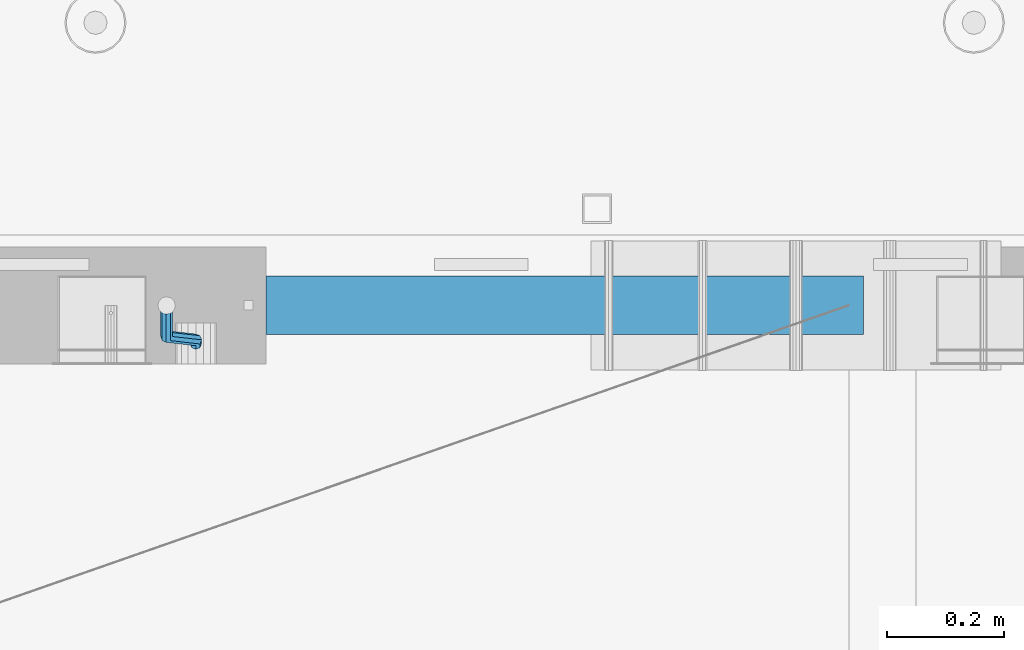
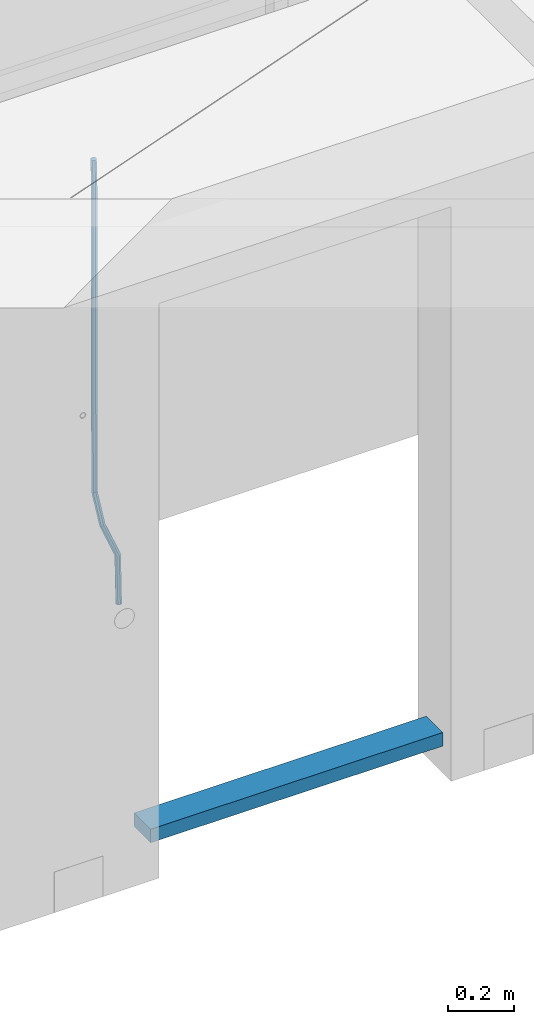
# One storey, part 112 of 349: 2 beams, 1 element without a shape of its own.
"""IFC2X3 building model written with IfcOpenShell, lengths in millimetres."""

import ifcopenshell
import ifcopenshell.guid

model = None  # the IFC model being written
_history = None  # IfcOwnerHistory: only IFC2X3 demands one
_inside = {}  # id of a spatial element -> (the spatial element, [elements in it])
_under = {}  # id of a project, library or spatial element -> (it, [spatial elements below it])
_declared = {}  # id of a project -> (the project, [libraries it declares])
_typed = {}  # id of a type object -> (the type object, [elements of that type])
_made_of = {}  # id of a material, layer set ... -> (it, [elements and type objects made of it])


def new_model(schema):
    """Start an empty IFC model of exactly this schema.

    Asked for "IFC4X3", IfcOpenShell would pick the latest addendum, in which some entities
    have other attributes; the version numbers below select the first issue.
    IFC2X3 requires an IfcOwnerHistory on every rooted entity: one is made here for all.
    """
    global model, _history
    if schema == "IFC4X3":
        model = ifcopenshell.file(schema_version=(4, 3, 0, 0))
    else:
        model = ifcopenshell.file(schema=schema)
    _inside.clear()
    _under.clear()
    _declared.clear()
    _typed.clear()
    _made_of.clear()
    _history = None
    if model.schema == "IFC2X3":
        org = make("IfcOrganization", Name="unknown")
        user = make(
            "IfcPersonAndOrganization",
            ThePerson=make("IfcPerson", FamilyName="unknown"),
            TheOrganization=org,
        )
        app = make(
            "IfcApplication",
            ApplicationDeveloper=org,
            Version="unknown",
            ApplicationFullName="unknown",
            ApplicationIdentifier="unknown",
        )
        _history = make(
            "IfcOwnerHistory",
            OwningUser=user,
            OwningApplication=app,
            ChangeAction="ADDED",
            CreationDate=0,
        )
    return model


def make(cls, **values):
    """One entity of the class cls with the attributes given. An attribute that is None is left unset."""
    return model.create_entity(
        cls, **{name: value for name, value in values.items() if value is not None}
    )


def rooted(cls, **values):
    """An entity with a GlobalId (a new one), such as an element, a storey or a relation."""
    return make(cls, GlobalId=ifcopenshell.guid.new(), OwnerHistory=_history, **values)


def si_unit(unit_type, name, prefix=None):
    """IfcSIUnit, for example si_unit("LENGTHUNIT", "METRE", prefix="MILLI")."""
    return make("IfcSIUnit", UnitType=unit_type, Prefix=prefix, Name=name)


def assignment(units):
    """IfcUnitAssignment: the units of a project."""
    return None if units is None else make("IfcUnitAssignment", Units=units)


def point(xyz):
    """IfcCartesianPoint."""
    return None if xyz is None else make("IfcCartesianPoint", Coordinates=xyz)


def direction(xyz):
    """IfcDirection."""
    return None if xyz is None else make("IfcDirection", DirectionRatios=xyz)


def frame(location, z_axis=None, x_axis=None):
    """IfcAxis2Placement3D, a coordinate frame: its origin and axes. An axis left out is left unset."""
    return make(
        "IfcAxis2Placement3D",
        Location=point(location),
        Axis=direction(z_axis),
        RefDirection=direction(x_axis),
    )


def origin_with_axes():
    """The frame at (0, 0, 0) with the z axis (0, 0, 1) and the x axis (1, 0, 0) written out."""
    return frame((0.0, 0.0, 0.0), z_axis=(0.0, 0.0, 1.0), x_axis=(1.0, 0.0, 0.0))


def place(relative_to, where):
    """IfcLocalPlacement: puts the frame where relative to a parent placement (None: the world)."""
    return make(
        "IfcLocalPlacement", PlacementRelTo=relative_to, RelativePlacement=where
    )


def context(
    kind, dimensions, precision=None, world=None, true_north=None, identifier=None
):
    """IfcGeometricRepresentationContext, for example the 3D "Model" context."""
    return make(
        "IfcGeometricRepresentationContext",
        ContextIdentifier=identifier,
        ContextType=kind,
        CoordinateSpaceDimension=dimensions,
        Precision=precision,
        WorldCoordinateSystem=world,
        TrueNorth=true_north,
    )


def subcontext(parent, identifier, kind, view, scale=None):
    """IfcGeometricRepresentationSubContext, for example "Body" below "Model"."""
    return make(
        "IfcGeometricRepresentationSubContext",
        ContextIdentifier=identifier,
        ContextType=kind,
        ParentContext=parent,
        TargetScale=scale,
        TargetView=view,
    )


def project(units=None, contexts=None):
    """IfcProject with its units and contexts."""
    return rooted(
        "IfcProject",
        Name="project",
        RepresentationContexts=contexts,
        UnitsInContext=assignment(units),
    )


def spatial(cls, under=None, at=None, **own):
    """A site, building, storey or space (cls), placed at a placement, below another one or the project."""
    s = rooted(cls, ObjectPlacement=at, **own)
    if under is not None:
        _under.setdefault(under.id(), (under, []))[1].append(s)
    return s


def faces_of(points, faces, orient=None, outer=None):
    """IfcFace entities. A face is a list of loops; a loop is a list of indices into points, from 0.

    orient and outer hold one flag for each loop. By default every Orientation is true, the
    first loop of a face is its IfcFaceOuterBound and the others are IfcFaceBound.
    """
    made = []
    for i, loops in enumerate(faces):
        bounds = []
        for j, loop in enumerate(loops):
            is_outer = j == 0 if outer is None else outer[i][j]
            bounds.append(
                make(
                    "IfcFaceOuterBound" if is_outer else "IfcFaceBound",
                    Bound=make("IfcPolyLoop", Polygon=[points[k] for k in loop]),
                    Orientation=True if orient is None else orient[i][j],
                )
            )
        made.append(make("IfcFace", Bounds=bounds))
    return made


def faceted_brep(points, faces, orient=None, outer=None, voids=None):
    """IfcFacetedBrep: a solid bounded by flat faces; with voids (closed shells), ...WithVoids."""
    shared = [point(p) for p in points]
    hull = make("IfcClosedShell", CfsFaces=faces_of(shared, faces, orient, outer))
    if voids is None:
        return make("IfcFacetedBrep", Outer=hull)
    return make(
        "IfcFacetedBrepWithVoids",
        Outer=hull,
        Voids=[
            make(cls, CfsFaces=faces_of(shared, fs, o, b)) for cls, fs, o, b in voids
        ],
    )


def shape(context_of_items, identifier, shape_type, items):
    """IfcShapeRepresentation: the items that make up one representation, for example the "Body"."""
    return make(
        "IfcShapeRepresentation",
        ContextOfItems=context_of_items,
        RepresentationIdentifier=identifier,
        RepresentationType=shape_type,
        Items=items,
    )


def material(Name=None, Category=None):
    """IfcMaterial."""
    return make("IfcMaterial", Name=Name, Category=Category)


def made_of(thing, what):
    """Note that an element or type object is made of a material, layer set ...; save() writes the relation."""
    if what is not None:
        _made_of.setdefault(what.id(), (what, []))[1].append(thing)
    return thing


def type_object(cls, material=None, **own):
    """A type object (cls), such as IfcWallType, which elements share."""
    return made_of(rooted(cls, **own), material)


def element(
    cls,
    number,
    at=None,
    inside=None,
    cuts=None,
    type_object=None,
    material=None,
    context=None,
    identifier="Body",
    shape_type=None,
    held_by="IfcProductDefinitionShape",
    body=None,
    shapes=None,
    **own,
):
    """One element of the class cls, such as IfcWall. Its Tag is "e" and its number.

    at: its placement. inside: the storey or other place that contains it. cuts: it is an
    opening in that element (IfcRelVoidsElement). A single representation is given by context,
    identifier, shape_type and body (its items); several are given by shapes. held_by: the class
    of the entity that holds the representations. save() writes the other relations.
    """
    e = rooted(cls, Tag="e%d" % number, ObjectPlacement=at, **own)
    if body is not None:
        shapes = [shape(context, identifier, shape_type, body)]
    if shapes is not None:
        e.Representation = make(held_by, Representations=shapes)
    if inside is not None:
        _inside.setdefault(inside.id(), (inside, []))[1].append(e)
    if cuts is not None:
        rooted(
            "IfcRelVoidsElement", RelatingBuildingElement=cuts, RelatedOpeningElement=e
        )
    if type_object is not None:
        _typed.setdefault(type_object.id(), (type_object, []))[1].append(e)
    return made_of(e, material)


def aggregate(whole, parts):
    """IfcRelAggregates: a whole, such as a stair, and the parts it consists of."""
    return rooted("IfcRelAggregates", RelatingObject=whole, RelatedObjects=parts)


def save(model, path):
    """Write the relations noted so far, then the file.

    IfcRelAggregates (storeys below a building ...), IfcRelContainedInSpatialStructure (elements
    in a storey), IfcRelDefinesByType, IfcRelAssociatesMaterial and IfcRelDeclares: one each for
    every whole, place, type object, material and project.
    """
    for whole, parts in _under.values():
        aggregate(whole, parts)
    for where, things in _inside.values():
        rooted(
            "IfcRelContainedInSpatialStructure",
            RelatedElements=things,
            RelatingStructure=where,
        )
    for kind, things in _typed.values():
        rooted("IfcRelDefinesByType", RelatedObjects=things, RelatingType=kind)
    for what, things in _made_of.values():
        rooted("IfcRelAssociatesMaterial", RelatedObjects=things, RelatingMaterial=what)
    for by, libraries in _declared.values():
        rooted("IfcRelDeclares", RelatingContext=by, RelatedDefinitions=libraries)
    model.write(path)


model = new_model("IFC2X3")

# Units and contexts
model_context = context("Model", 3, precision=1e-05, world=origin_with_axes())
body_context = subcontext(model_context, "Body", "Model", "MODEL_VIEW")
ifc_project = project(units=[si_unit("LENGTHUNIT", "METRE", prefix="MILLI"), si_unit("AREAUNIT", "SQUARE_METRE"), si_unit("VOLUMEUNIT", "CUBIC_METRE"), si_unit("MASSUNIT", "GRAM", prefix="KILO"), si_unit("TIMEUNIT", "SECOND"), si_unit("PLANEANGLEUNIT", "RADIAN"), si_unit("SOLIDANGLEUNIT", "STERADIAN"), si_unit("THERMODYNAMICTEMPERATUREUNIT", "DEGREE_CELSIUS"), si_unit("LUMINOUSINTENSITYUNIT", "LUMEN")], contexts=[model_context])

# Site, building, storey
site_placement = place(None, origin_with_axes())
site = spatial("IfcSite", under=ifc_project, at=site_placement, CompositionType="ELEMENT")
building_placement = place(site_placement, origin_with_axes())
building = spatial("IfcBuilding", under=site, at=building_placement, CompositionType="ELEMENT")
storey_placement = place(building_placement, origin_with_axes())
storey = spatial("IfcBuildingStorey", under=building, at=storey_placement, Name="4", CompositionType="ELEMENT", Elevation=0.0)

# Assembly, beams
assembly_placement = place(storey_placement, origin_with_axes())
assembly = element("IfcElementAssembly", 1, at=assembly_placement, inside=storey, AssemblyPlace="NOTDEFINED", PredefinedType="REINFORCEMENT_UNIT")
ifc_material_1 = material()
beam_type_1 = type_object("IfcBeamType", Name="D20", PredefinedType="NOTDEFINED")
beam_1_placement = place(assembly_placement, frame((24379.9991455117, 15114.989587991, 91790.0076324386), z_axis=(-0.000205762999925498, 0.999642804629538, -0.0267249099901004), x_axis=(4.30000201928125e-08, 0.0267249099948059, 0.999642825806181)))
beam_1 = element("IfcBeam", 2, at=beam_1_placement, type_object=beam_type_1, material=ifc_material_1, Name="JM20", ObjectType="D20", context=body_context, shape_type="Brep", body=[
    faceted_brep([(0.0, -10.0, 0.0), (-4.19531716033816e-08, -7.07106781186667, -7.07106781187031), (60.4266690400545, -7.0710677960451, -7.07106780570757), (60.4266690441291, -9.99999998418934, 6.15546014159918e-09), (0.0, 0.0, -10.0), (60.426669036824, 1.58106558956206e-08, -9.99999999384454), (4.196772351861e-08, 7.07106781186303, -7.07106781186667), (60.4266690363438, 7.07106782768096, -7.07106780570757), (0.0, 10.0, 0.0), (60.4266690388904, 10.0000000158179, 6.15182216279209e-09), (4.196772351861e-08, 7.07106781185939, 7.07106781185939), (60.4266690429649, 7.07106782768096, 7.07106781802577), (0.0, 0.0, 10.0), (60.4266690461809, 1.58179318532348e-08, 10.0000000061555), (-4.19531716033816e-08, -7.07106781187031, 7.07106781185939), (60.4266690466611, -7.07106779605238, 7.07106781802213), (61.0378400410118, -7.07106779588503, -7.07106780564936), (60.991799419251, -9.99999998403655, 6.21366780251265e-09), (61.0569027789461, 1.5985278878361e-08, -9.99999999378269), (61.0378209396877, 7.07106782784831, -7.07106780564936), (60.9917724058905, 10.0000000159635, 6.21366780251265e-09), (60.9457317841297, 7.07106782781193, 7.0710678180767), (60.9266690461809, 1.59488990902901e-08, 10.0000000062028), (60.9457508854539, -7.07106779591413, 7.0710678180767), (61.6489592143771, -7.07106614513759, -7.06310863441468), (61.5568818710308, -9.9999984576425, 0.00735959856683621), (61.6870830769039, 1.71821739058942e-06, -9.99179257185824), (61.6489210170112, 7.07106947854481, -7.06310888312146), (61.556827851804, 10.0000015422847, 0.00735924683976918), (61.4647505084577, 7.07106922979438, 7.07782747982128), (61.4266266459163, 1.36643211590126e-06, 10.0065114172685), (61.464788705809, -7.07106639389531, 7.07782772852806), (174.621213165461, -7.07076098345351, -5.59176629582907), (174.529135822144, -9.99969329595478, 1.4787019371488), (174.659337027944, 0.000306879905110691, -8.52045023327446), (174.621174967935, 7.07137464022526, -5.59176654453404), (174.529081802684, 10.0003067039688, 1.47870158543083), (174.437004459352, 7.07137439147118, 8.5491698184087), (174.398880596913, 0.000306528108922066, 11.4778537558541), (174.437042656878, -7.07076123221123, 8.54917006711185), (175.716094779258, -7.07075802595864, -5.57750663810293), (175.029093421879, -9.99969194546793, 1.48521334821271), (177.145578432857, 0.000313595744955819, -8.48806960781258), (178.480172245545, 7.07138506415868, -5.54150724740612), (178.938089262141, 10.0003186135946, 1.53612417477052), (178.251087904748, 7.07138469408164, 8.59884416108434), (176.821604251149, 0.000313072378048673, 11.5094071307958), (175.487010438475, -7.07075839603567, 8.56284477038935), (176.73028205616, -7.48306481911277, -5.5575978012148), (175.49220343327, -10.1879642774365, 1.49430435328395), (179.448580299344, -0.935946733912715, -8.44286090764945), (182.054755918522, 5.61817699831226, -5.47133696928722), (183.022146581905, 8.33998958468874, 1.61629559169705), (181.784067959001, 5.63509012636496, 8.6681977461958), (179.065769715831, -0.912027958831459, 11.5534608526305), (176.459594096654, -7.4661516910528, 8.58193691426459), (294.295456565174, -55.2779062578775, -3.24975393820569), (293.057377942285, -57.9828057162013, 3.80214821629306), (297.013754808359, -48.7307881726811, -6.13501704463852), (299.619930427536, -42.1766644404597, -3.16349310627629), (300.587321090919, -39.454851854076, 3.92413945470616), (299.34924246803, -42.1597513124034, 10.9760416092031), (296.630944224846, -48.7068693975998, 13.8613047156396), (294.024768605668, -55.2609931298248, 10.8897807772755), (300.131186042752, -57.6503585272258, -3.13519660847487), (297.927214299008, -59.9625846556301, 3.89774473963917), (302.241773597852, -50.8561822796182, -6.0323892798333), (303.022623399127, -43.5599922135116, -3.09669710035814), (302.016324223136, -40.0357975159677, 3.95219126616212), (299.812352479406, -42.3480236443684, 10.9851326142743), (297.701764924292, -49.1421998919686, 13.8823252856328), (296.920915123032, -56.4383899580826, 10.9466331061594), (305.816309115588, -57.6497962814865, -0.41917616768842), (302.671371672826, -59.9621154692577, 6.16422661461002), (307.334869561208, -50.8556785840192, -3.59920488503303), (306.337500895927, -43.5596643796707, -1.51304184353285), (303.408448157163, -40.0356598380822, 4.61726694041863), (300.263510714387, -42.3479790258461, 11.2006697227207), (298.744950268767, -49.1420967233171, 14.3806984400617), (299.742318934063, -56.4381109276655, 12.2945353985633), (395.630203780689, -57.6409138916788, 42.488667805259), (392.485266337913, -59.9532330794427, 49.0720705875574), (397.148764226309, -50.8467961942151, 39.3086390879143), (396.151395561013, -43.5507819898594, 41.3948021294145), (393.22234282225, -40.0267774482672, 47.5251109133696), (390.077405379474, -42.3390966360348, 54.1085136956717), (388.558844933854, -49.1332143335057, 57.2885424130127), (389.556213599149, -56.4292285378579, 55.2023793715125), (396.844209099741, -57.640793829316, 43.0686487871244), (395.280625423067, -59.9529566247911, 50.4075302279853), (397.599922461304, -50.8467515756856, 39.5241761963625), (397.10507886979, -43.5506876727486, 41.8504164279075), (395.649550989881, -40.0265374029004, 48.6846895034632), (394.085967313207, -42.3387001983865, 56.0235709443259), (393.330253951674, -49.1327424520096, 59.5680435350878), (393.825097543173, -56.4288063549466, 57.241803303541), (398.189189358192, -57.6411602552034, 43.0337942646147), (398.377566371972, -59.9538003541529, 50.3272744790011), (398.099754636642, -50.8468877497689, 39.5112232837091), (398.161651854258, -43.550975525075, 41.8230358424771), (398.338622460418, -40.027270012466, 48.6150034976581), (398.526999474212, -42.3399101114192, 55.9084837120445), (398.616434195777, -49.13418261685, 59.4310546929501), (398.554536978161, -56.4300948415512, 57.1192421341821), (1517.19478070838, -57.9460216934422, 14.0352975759452), (1517.38315772217, -60.2586617923953, 21.3287777903333), (1517.10534598683, -51.1517491880113, 10.5127265950414), (1517.16724320444, -43.8558369633138, 12.8245391538094), (1517.34421381062, -40.3321314507048, 19.6165068089904), (1517.53259082441, -42.6447715496579, 26.9099870233767), (1517.62202554596, -49.4390440550887, 30.4325580042841), (1517.56012832835, -56.7349562797899, 28.1207454455143), (1518.02724982343, -57.946248491, 14.0137245355054), (1518.07759034891, -60.258850983344, 21.3107818997123), (1517.99524544395, -51.1519916318648, 10.4896652746502), (1518.00032494192, -43.8560639277712, 12.8029502375484), (1518.03951281632, -40.3323208776928, 19.5984884665704), (1518.08985334181, -42.6449233700369, 26.8955458307773), (1518.12185772131, -49.4391802291757, 30.4196050916289), (1518.11677822332, -56.735107933262, 28.1063201287325), (1518.85992470267, -57.9437654472204, 14.0245252313944), (1518.77219462092, -60.2567796673247, 21.3197916701429), (1518.8853648605, -51.149337287974, 10.5012110884654), (1518.83361259502, -43.8535790567003, 12.8137588817826), (1518.73498368141, -40.3302469774862, 19.6075094776534), (1518.64725359967, -42.6432611975906, 26.9027759164019), (1518.62181344185, -49.4376893568369, 30.4260900593326), (1518.67356570732, -56.7334475881107, 28.1135422660154), (1618.76572350181, -57.6458454809253, 15.3204117501973), (1618.67799342007, -59.9588597010261, 22.6156781889458), (1618.79116365965, -50.8514173216718, 11.7970976072666), (1618.73941139416, -43.5556590904016, 14.1096454005838), (1618.64078248056, -40.032327011184, 20.9033959964545), (1618.55305239883, -42.3453412312883, 28.198662435203), (1618.52761224099, -49.1397693905419, 31.7219765781338), (1618.57936450648, -56.4355276218121, 29.4094287848166)], [[[0, 1, 2, 3]], [[1, 4, 5, 2]], [[4, 6, 7, 5]], [[6, 8, 9, 7]], [[8, 10, 11, 9]], [[10, 12, 13, 11]], [[12, 14, 15, 13]], [[14, 0, 3, 15]], [[14, 12, 10, 8, 6, 4, 1, 0]], [[3, 2, 16, 17]], [[2, 5, 18, 16]], [[5, 7, 19, 18]], [[7, 9, 20, 19]], [[9, 11, 21, 20]], [[11, 13, 22, 21]], [[13, 15, 23, 22]], [[15, 3, 17, 23]], [[17, 16, 24, 25]], [[16, 18, 26, 24]], [[18, 19, 27, 26]], [[19, 20, 28, 27]], [[20, 21, 29, 28]], [[21, 22, 30, 29]], [[22, 23, 31, 30]], [[23, 17, 25, 31]], [[25, 24, 32, 33]], [[24, 26, 34, 32]], [[26, 27, 35, 34]], [[27, 28, 36, 35]], [[28, 29, 37, 36]], [[29, 30, 38, 37]], [[30, 31, 39, 38]], [[31, 25, 33, 39]], [[33, 32, 40, 41]], [[32, 34, 42, 40]], [[34, 35, 43, 42]], [[35, 36, 44, 43]], [[36, 37, 45, 44]], [[37, 38, 46, 45]], [[38, 39, 47, 46]], [[39, 33, 41, 47]], [[41, 40, 48, 49]], [[40, 42, 50, 48]], [[42, 43, 51, 50]], [[43, 44, 52, 51]], [[44, 45, 53, 52]], [[45, 46, 54, 53]], [[46, 47, 55, 54]], [[47, 41, 49, 55]], [[49, 48, 56, 57]], [[48, 50, 58, 56]], [[50, 51, 59, 58]], [[51, 52, 60, 59]], [[52, 53, 61, 60]], [[53, 54, 62, 61]], [[54, 55, 63, 62]], [[55, 49, 57, 63]], [[57, 56, 64, 65]], [[56, 58, 66, 64]], [[58, 59, 67, 66]], [[59, 60, 68, 67]], [[60, 61, 69, 68]], [[61, 62, 70, 69]], [[62, 63, 71, 70]], [[63, 57, 65, 71]], [[65, 64, 72, 73]], [[64, 66, 74, 72]], [[66, 67, 75, 74]], [[67, 68, 76, 75]], [[68, 69, 77, 76]], [[69, 70, 78, 77]], [[70, 71, 79, 78]], [[71, 65, 73, 79]], [[73, 72, 80, 81]], [[72, 74, 82, 80]], [[74, 75, 83, 82]], [[75, 76, 84, 83]], [[76, 77, 85, 84]], [[77, 78, 86, 85]], [[78, 79, 87, 86]], [[79, 73, 81, 87]], [[81, 80, 88, 89]], [[80, 82, 90, 88]], [[82, 83, 91, 90]], [[83, 84, 92, 91]], [[84, 85, 93, 92]], [[85, 86, 94, 93]], [[86, 87, 95, 94]], [[87, 81, 89, 95]], [[89, 88, 96, 97]], [[88, 90, 98, 96]], [[90, 91, 99, 98]], [[91, 92, 100, 99]], [[92, 93, 101, 100]], [[93, 94, 102, 101]], [[94, 95, 103, 102]], [[95, 89, 97, 103]], [[97, 96, 104, 105]], [[96, 98, 106, 104]], [[98, 99, 107, 106]], [[99, 100, 108, 107]], [[100, 101, 109, 108]], [[101, 102, 110, 109]], [[102, 103, 111, 110]], [[103, 97, 105, 111]], [[105, 104, 112, 113]], [[104, 106, 114, 112]], [[106, 107, 115, 114]], [[107, 108, 116, 115]], [[108, 109, 117, 116]], [[109, 110, 118, 117]], [[110, 111, 119, 118]], [[111, 105, 113, 119]], [[113, 112, 120, 121]], [[112, 114, 122, 120]], [[114, 115, 123, 122]], [[115, 116, 124, 123]], [[116, 117, 125, 124]], [[117, 118, 126, 125]], [[118, 119, 127, 126]], [[119, 113, 121, 127]], [[121, 120, 128, 129]], [[120, 122, 130, 128]], [[122, 123, 131, 130]], [[123, 124, 132, 131]], [[124, 125, 133, 132]], [[125, 126, 134, 133]], [[126, 127, 135, 134]], [[127, 121, 129, 135]], [[130, 131, 132, 133, 134, 135, 129, 128]]]),
])
ifc_material_2 = material(Name="TIMBER/T24")
beam_type_2 = type_object("IfcBeamType", PredefinedType="NOTDEFINED")
beam_2_placement = place(assembly_placement, frame((24500.0006866455, 15180.0, 90880.0), z_axis=(0.0, 0.0, 1.0), x_axis=(1.0, 0.0, 0.0)))
beam_2 = element("IfcBeam", 3, at=beam_2_placement, type_object=beam_type_2, material=ifc_material_2, context=body_context, shape_type="Brep", body=[
    faceted_brep([(0.0, 50.0, -25.0), (0.0, 50.0, 25.0), (1020.0, 50.0, 25.0), (1020.0, 50.0, -25.0), (0.0, -50.0, 25.0), (1020.0, -50.0, 25.0), (0.0, -50.0, -25.0), (1020.0, -50.0, -25.0)], [[[0, 1, 2, 3]], [[1, 4, 5, 2]], [[4, 6, 7, 5]], [[6, 0, 3, 7]], [[5, 7, 3, 2]], [[6, 4, 1, 0]]]),
])
aggregate(assembly, [beam_1, beam_2])

save(model, "model.ifc")
